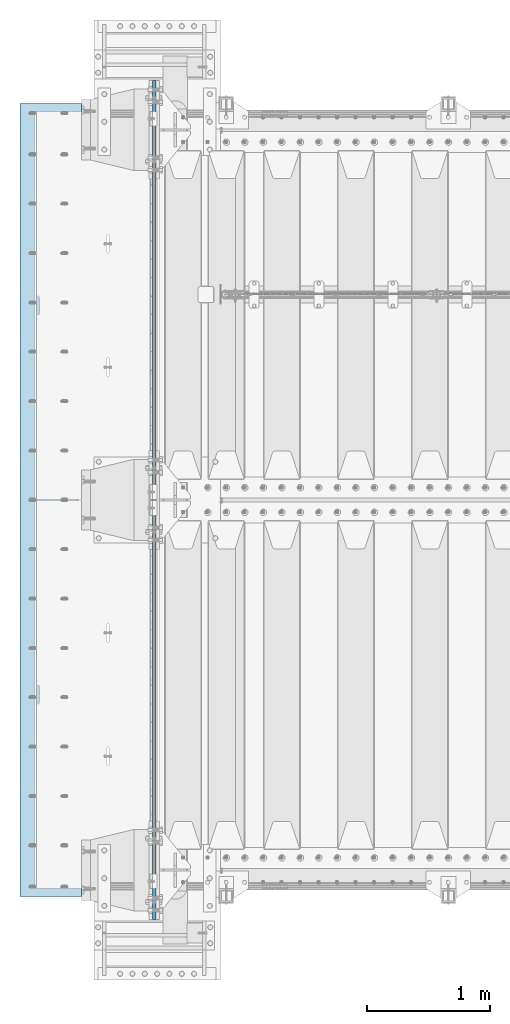
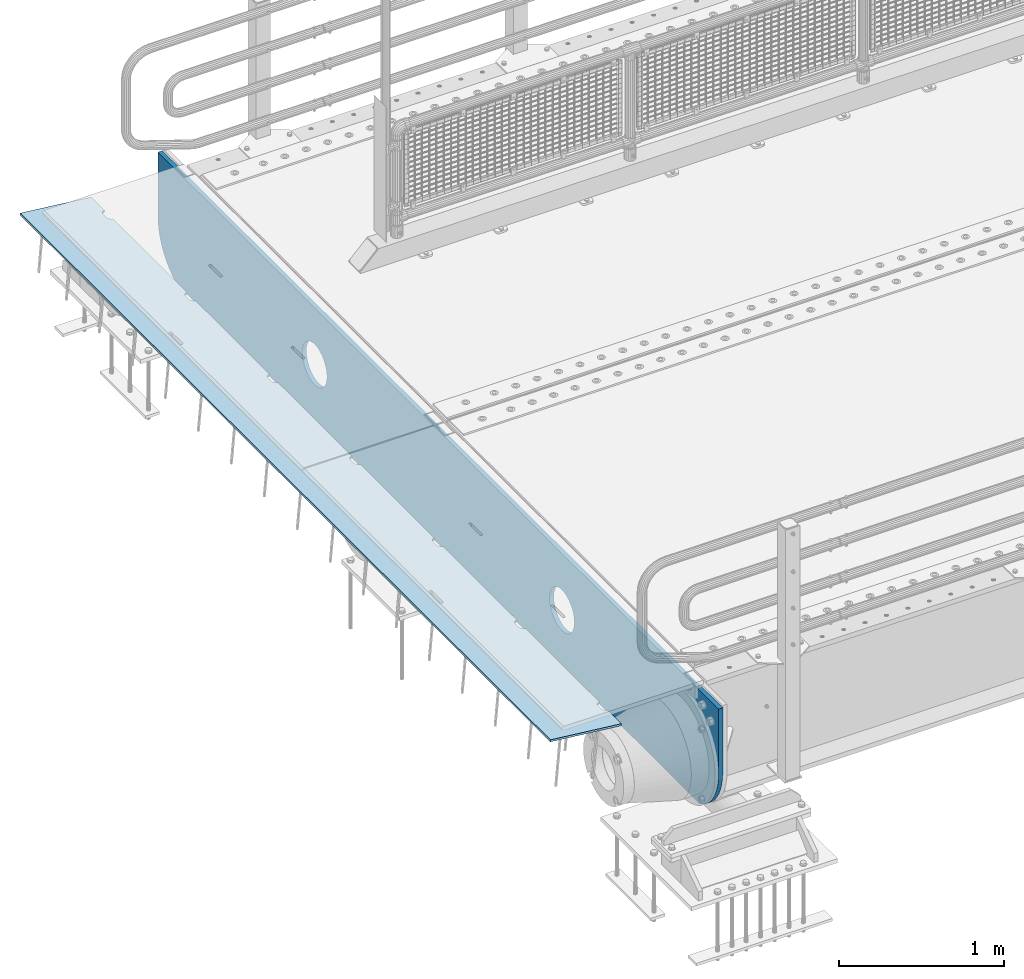
# One storey, part 191 of 242: 2 plates.
"""IFC2X3 building model written with IfcOpenShell, lengths in millimetres."""

from ifc_helpers import new_model, si_unit, frame, origin_with_axes, place, context, subcontext, project, spatial, faceted_brep, material, type_object, element, save


model = new_model("IFC2X3")

# Units and contexts
model_context = context("Model", 3, precision=1e-05, world=origin_with_axes())
body_context = subcontext(model_context, "Body", "Model", "MODEL_VIEW")
ifc_project = project(units=[si_unit("LENGTHUNIT", "METRE", prefix="MILLI"), si_unit("AREAUNIT", "SQUARE_METRE"), si_unit("VOLUMEUNIT", "CUBIC_METRE"), si_unit("MASSUNIT", "GRAM", prefix="KILO"), si_unit("TIMEUNIT", "SECOND"), si_unit("PLANEANGLEUNIT", "RADIAN"), si_unit("SOLIDANGLEUNIT", "STERADIAN"), si_unit("THERMODYNAMICTEMPERATUREUNIT", "DEGREE_CELSIUS"), si_unit("LUMINOUSINTENSITYUNIT", "LUMEN")], contexts=[model_context])

# Site, building, storey
site_placement = place(None, origin_with_axes())
site = spatial("IfcSite", under=ifc_project, at=site_placement, CompositionType="ELEMENT")
building_placement = place(site_placement, origin_with_axes())
building = spatial("IfcBuilding", under=site, at=building_placement, Name="Standard", CompositionType="ELEMENT")
storey_placement = place(building_placement, origin_with_axes())
storey = spatial("IfcBuildingStorey", under=building, at=storey_placement, Name="Undefined", CompositionType="ELEMENT", Elevation=0.0)

# Plates
ifc_material = material(Name="STEEL/S355N")
plate_type_1 = type_object("IfcPlateType", PredefinedType="NOTDEFINED")
plate_1_placement = place(storey_placement, frame((-42485.0, -24400.0, -35.9999830912049), z_axis=(0.0, 1.0, 0.0), x_axis=(0.0, 0.0, -1.0)))
element("IfcPlate", 1, at=plate_1_placement, inside=storey, type_object=plate_type_1, material=ifc_material, context=body_context, shape_type="Brep", body=[
    faceted_brep([(449.263580031862, -15.0, 2047.11778936592), (449.263580031862, 15.0, 2047.11778936592), (477.402546532991, 15.0, 2038.58192701329), (477.402546532991, -15.0, 2038.58192701329), (503.335566547999, 15.0, 2024.72043882638), (503.335566547999, -15.0, 2024.72043882638), (526.066048661114, 15.0, 2006.0660140226), (526.066048661114, -15.0, 2006.0660140226), (544.720473192131, 15.0, 1983.33553168563), (544.720473192131, -15.0, 1983.33553168563), (558.581961067844, 15.0, 1957.40251150429), (558.581961067844, -15.0, 1957.40251150429), (567.117823082802, 15.0, 1929.26354490073), (567.117823082802, -15.0, 1929.26354490073), (570.000030846736, 15.0, 1899.99999658101), (570.000030846736, -15.0, 1899.99999658101), (567.117822731639, 15.0, 1870.73644829589), (567.117822731639, -15.0, 1870.73644829589), (558.581960379014, 15.0, 1842.59748179476), (558.581960379014, -15.0, 1842.59748179476), (544.720472192104, 15.0, 1816.66446177975), (544.720472192104, -15.0, 1816.66446177975), (526.066047388322, 15.0, 1793.93397966664), (526.066047388322, -15.0, 1793.93397966664), (503.335565051353, 15.0, 1775.27955513562), (503.335565051353, -15.0, 1775.27955513562), (477.402544870008, 15.0, 1761.4180672599), (477.402544870008, -15.0, 1761.4180672599), (449.263578266448, 15.0, 1752.88220524495), (449.263578266448, -15.0, 1752.88220524495), (420.000029946736, 15.0, 1749.99999748101), (420.000029946736, -15.0, 1749.99999748101), (390.73648166161, 15.0, 1752.88220559611), (390.73648166161, -15.0, 1752.88220559611), (362.597515160481, 15.0, 1761.41806794873), (362.597515160481, -15.0, 1761.41806794873), (336.664495145473, 15.0, 1775.27955613565), (336.664495145473, -15.0, 1775.27955613565), (313.934013032358, 15.0, 1793.93398093943), (313.934013032358, -15.0, 1793.93398093943), (295.279588501341, 15.0, 1816.6644632764), (295.279588501341, -15.0, 1816.6644632764), (281.418100625628, 15.0, 1842.59748345774), (281.418100625628, -15.0, 1842.59748345774), (272.88223861067, 15.0, 1870.7364500613), (272.88223861067, -15.0, 1870.7364500613), (270.000030846736, 15.0, 1899.99999838101), (270.000030846736, -15.0, 1899.99999838101), (272.882238961832, 15.0, 1929.26354666614), (272.882238961832, -15.0, 1929.26354666614), (281.418101314458, 15.0, 1957.40251316727), (281.418101314458, -15.0, 1957.40251316727), (295.279589501367, 15.0, 1983.33553318228), (295.279589501367, -15.0, 1983.33553318228), (313.93401430515, 15.0, 2006.06601529539), (313.93401430515, -15.0, 2006.06601529539), (336.664496642118, 15.0, 2024.72043982641), (336.664496642118, -15.0, 2024.72043982641), (362.597516823464, 15.0, 2038.58192770212), (362.597516823464, -15.0, 2038.58192770212), (390.736483427023, 15.0, 2047.11778971708), (390.736483427023, -15.0, 2047.11778971708), (420.000031746736, 15.0, 2049.99999748101), (420.000031746736, -15.0, 2049.99999748101), (-9.46818609293132e-07, 15.0, 6800.0), (-9.46818609293132e-07, -15.0, 6800.0), (479.000057698974, -15.0, 6799.9999971271), (479.000057668868, 15.0, 6800.0), (0.0, -15.0, 0.0), (0.0, 15.0, 0.0), (479.000000000116, 15.0, 0.0), (479.000000000116, -15.0, 0.0), (527.214672104542, 15.0, 2.9164503635111), (527.214672104542, -15.0, 2.9164503635111), (574.72626571721, 15.0, 11.6232730319753), (574.72626571721, -15.0, 11.6232730319753), (620.841954818999, 15.0, 25.9935029278749), (620.841954818999, -15.0, 25.9935029278749), (664.889268819315, 15.0, 45.8175897403853), (664.889268819315, -15.0, 45.8175897403853), (706.225898694119, 15.0, 70.8064536438214), (706.225898694119, -15.0, 70.8064536438214), (744.249063297851, 15.0, 100.595700732451), (744.249063297851, -15.0, 100.595700732451), (778.404299269879, 15.0, 134.750936704171), (778.404299269879, -15.0, 134.750936704171), (808.193546358832, 15.0, 172.77410130763), (808.193546358832, -15.0, 172.77410130763), (833.182410262612, 15.0, 214.110731182191), (833.182410262612, -15.0, 214.110731182191), (838.999997962172, -15.0, 227.036880797281), (838.999997962172, 15.0, 227.036880797281), (838.999941002682, 15.0, 6572.96326471486), (838.999941002682, -15.0, 6572.96326478152), (833.182425778571, 14.9999999999927, 6585.88925446616), (833.182425808571, -15.0000000000073, 6585.88925446616), (808.193562547503, 14.9999999999927, 6627.22588611703), (808.193562577503, -15.0000000000073, 6627.22588611703), (778.40431580068, 14.9999999999927, 6665.24905247753), (778.40431583068, -15.0000000000073, 6665.24905247753), (744.249079856288, 14.9999999999927, 6699.40429013451), (744.249079886288, -15.0000000000073, 6699.40429013451), (706.225914989459, 14.9999999999927, 6729.19353878786), (706.225915019459, -15.0000000000073, 6729.19353878786), (664.889284591557, 14.9999999999927, 6754.18240409161), (664.889284621557, -15.0000000000073, 6754.18240409161), (620.841969845021, 14.9999999999927, 6774.00649210192), (620.841969875021, -15.0000000000073, 6774.00649210192), (574.726279815927, 14.9999999999927, 6788.37672296161), (574.726279845927, -15.0000000000073, 6788.37672296161), (527.214685141022, 14.9999999999927, 6797.08354633565), (527.214685171022, -15.0000000000073, 6797.08354633565), (477.402561983564, -15.0, 5038.58192701329), (503.335581998572, -15.0, 5024.72043882638), (526.066064111687, -15.0, 5006.0660140226), (544.720488642704, -15.0, 4983.33553168563), (558.581976518417, -15.0, 4957.40251150429), (567.117838533375, -15.0, 4929.26354490073), (570.000046297309, -15.0, 4899.99999658101), (567.117838182212, -15.0, 4870.73644829589), (558.581975829587, -15.0, 4842.59748179476), (544.720487642677, -15.0, 4816.66446177975), (526.066062838895, -15.0, 4793.93397966664), (503.335580501926, -15.0, 4775.27955513562), (477.402560320581, -15.0, 4761.4180672599), (449.263593717021, -15.0, 4752.88220524495), (420.000045397309, -15.0, 4749.99999748101), (390.736497112183, -15.0, 4752.88220559611), (362.597530611054, -15.0, 4761.41806794873), (336.664510596046, -15.0, 4775.27955613565), (313.93402848293, -15.0, 4793.93398093943), (295.279603951914, -15.0, 4816.6644632764), (281.418116076201, -15.0, 4842.59748345774), (272.882254061243, -15.0, 4870.7364500613), (270.000046297309, -15.0, 4899.99999838101), (272.882254412405, -15.0, 4929.26354666614), (281.418116765031, -15.0, 4957.40251316727), (295.27960495194, -15.0, 4983.33553318228), (313.934029755723, -15.0, 5006.06601529539), (336.664512092691, -15.0, 5024.72043982641), (362.597532274037, -15.0, 5038.58192770212), (390.736498877596, -15.0, 5047.11778971708), (420.000047197309, -15.0, 5049.99999748101), (449.263595482435, -15.0, 5047.11778936592), (362.597532274037, 15.0, 5038.58192770212), (390.736498877596, 15.0, 5047.11778971708), (336.664512092691, 15.0, 5024.72043982641), (313.934029755723, 15.0, 5006.06601529539), (295.27960495194, 15.0, 4983.33553318228), (281.418116765031, 15.0, 4957.40251316727), (272.882254412405, 15.0, 4929.26354666614), (270.000046297309, 15.0, 4899.99999838101), (272.882254061243, 15.0, 4870.7364500613), (281.418116076201, 15.0, 4842.59748345774), (295.279603951914, 15.0, 4816.6644632764), (313.93402848293, 15.0, 4793.93398093943), (336.664510596046, 15.0, 4775.27955613565), (362.597530611054, 15.0, 4761.41806794873), (390.736497112183, 15.0, 4752.88220559611), (420.000045397309, 15.0, 4749.99999748101), (449.263593717021, 15.0, 4752.88220524495), (477.402560320581, 15.0, 4761.4180672599), (503.335580501926, 15.0, 4775.27955513562), (526.066062838895, 15.0, 4793.93397966664), (544.720487642677, 15.0, 4816.66446177975), (558.581975829587, 15.0, 4842.59748179476), (567.117838182212, 15.0, 4870.73644829589), (570.000046297309, 15.0, 4899.99999658101), (567.117838533375, 15.0, 4929.26354490073), (558.581976518417, 15.0, 4957.40251150429), (544.720488642704, 15.0, 4983.33553168563), (526.066064111687, 15.0, 5006.0660140226), (503.335581998572, 15.0, 5024.72043882638), (477.402561983564, 15.0, 5038.58192701329), (449.263595482435, 15.0, 5047.11778936592), (420.000047197309, 15.0, 5049.99999748101)], [[[0, 1, 2, 3]], [[3, 2, 4, 5]], [[5, 4, 6, 7]], [[7, 6, 8, 9]], [[9, 8, 10, 11]], [[11, 10, 12, 13]], [[13, 12, 14, 15]], [[15, 14, 16, 17]], [[17, 16, 18, 19]], [[19, 18, 20, 21]], [[21, 20, 22, 23]], [[23, 22, 24, 25]], [[25, 24, 26, 27]], [[27, 26, 28, 29]], [[29, 28, 30, 31]], [[31, 30, 32, 33]], [[33, 32, 34, 35]], [[35, 34, 36, 37]], [[37, 36, 38, 39]], [[39, 38, 40, 41]], [[41, 40, 42, 43]], [[43, 42, 44, 45]], [[45, 44, 46, 47]], [[47, 46, 48, 49]], [[49, 48, 50, 51]], [[51, 50, 52, 53]], [[53, 52, 54, 55]], [[55, 54, 56, 57]], [[57, 56, 58, 59]], [[59, 58, 60, 61]], [[61, 60, 62, 63]], [[63, 62, 1, 0]], [[64, 65, 66, 67]], [[68, 65, 64, 69]], [[68, 69, 70, 71]], [[71, 70, 72, 73]], [[73, 72, 74, 75]], [[75, 74, 76, 77]], [[77, 76, 78, 79]], [[79, 78, 80, 81]], [[81, 80, 82, 83]], [[83, 82, 84, 85]], [[85, 84, 86, 87]], [[87, 86, 88, 89]], [[90, 89, 88, 91]], [[90, 91, 92, 93]], [[93, 92, 94, 95]], [[95, 94, 96, 97]], [[97, 96, 98, 99]], [[99, 98, 100, 101]], [[101, 100, 102, 103]], [[103, 102, 104, 105]], [[105, 104, 106, 107]], [[107, 106, 108, 109]], [[109, 108, 110, 111]], [[66, 111, 110, 67]], [[65, 68, 71, 73, 75, 77, 79, 81, 83, 85, 87, 89, 90, 93, 95, 97, 99, 101, 103, 105, 107, 109, 111, 66], [3, 5, 7, 9, 11, 13, 15, 17, 19, 21, 23, 25, 27, 29, 31, 33, 35, 37, 39, 41, 43, 45, 47, 49, 51, 53, 55, 57, 59, 61, 63, 0], [112, 113, 114, 115, 116, 117, 118, 119, 120, 121, 122, 123, 124, 125, 126, 127, 128, 129, 130, 131, 132, 133, 134, 135, 136, 137, 138, 139, 140, 141, 142, 143]], [[140, 144, 145, 141]], [[139, 146, 144, 140]], [[138, 147, 146, 139]], [[137, 148, 147, 138]], [[136, 149, 148, 137]], [[135, 150, 149, 136]], [[134, 151, 150, 135]], [[133, 152, 151, 134]], [[132, 153, 152, 133]], [[131, 154, 153, 132]], [[130, 155, 154, 131]], [[129, 156, 155, 130]], [[128, 157, 156, 129]], [[127, 158, 157, 128]], [[126, 159, 158, 127]], [[125, 160, 159, 126]], [[124, 161, 160, 125]], [[123, 162, 161, 124]], [[122, 163, 162, 123]], [[121, 164, 163, 122]], [[120, 165, 164, 121]], [[119, 166, 165, 120]], [[118, 167, 166, 119]], [[117, 168, 167, 118]], [[116, 169, 168, 117]], [[115, 170, 169, 116]], [[114, 171, 170, 115]], [[113, 172, 171, 114]], [[112, 173, 172, 113]], [[143, 174, 173, 112]], [[142, 175, 174, 143]], [[141, 145, 175, 142]], [[108, 106, 104, 102, 100, 98, 96, 94, 92, 91, 88, 86, 84, 82, 80, 78, 76, 74, 72, 70, 69, 64, 67, 110], [58, 56, 54, 52, 50, 48, 46, 44, 42, 40, 38, 36, 34, 32, 30, 28, 26, 24, 22, 20, 18, 16, 14, 12, 10, 8, 6, 4, 2, 1, 62, 60], [144, 146, 147, 148, 149, 150, 151, 152, 153, 154, 155, 156, 157, 158, 159, 160, 161, 162, 163, 164, 165, 166, 167, 168, 169, 170, 171, 172, 173, 174, 175, 145]]]),
])
plate_type_2 = type_object("IfcPlateType", PredefinedType="NOTDEFINED")
plate_2_placement = place(storey_placement, frame((-43074.1812549702, -24215.0, -62.544823504668), z_axis=(-0.994023532708189, -4.00000135296876e-09, 0.109166003967953), x_axis=(0.0, 1.0, 0.0)))
element("IfcPlate", 2, at=plate_2_placement, inside=storey, type_object=plate_type_2, material=ifc_material, context=body_context, shape_type="Brep", body=[
    faceted_brep([(6164.99999999666, -7.49999999999909, 7.33479246264324e-05), (6165.00000000327, 7.50000000000091, -2.18278728425503e-11), (6165.45576743374, 7.5, 5.20976320983755), (6165.4557674272, -7.50000000000091, 5.20976320983755), (6166.80922142074, 7.5, 10.2609221742096), (6166.80922141419, -7.49999999999909, 10.2609221742168), (6169.01923794974, 7.49999999999909, 15.0003178656552), (6169.01923794319, -7.5, 15.0003178656552), (6172.01866678684, 7.5, 19.2839461443291), (6172.01866678029, -7.5, 19.2839461443291), (6175.71637180461, 7.50000000000091, 22.9816511325989), (6175.71637179805, -7.49999999999818, 22.9816511325989), (6180.0000001072, 7.5, 25.9810799355328), (6180.00000010065, -7.5, 25.98107993554), (6184.73939581627, 7.5, 28.1910964267299), (6184.73939580972, -7.49999999999909, 28.1910964267299), (6189.79055479144, 7.50000000000091, 29.5445503734372), (6189.79055478489, -7.49999999999818, 29.5445503734372), (6195.00000012327, 7.50000000000091, 30.0003177623585), (6195.00000011672, -7.49999999999818, 30.0003177623657), (6235.00000012327, 7.50000000000182, 30.0003176033133), (6235.00000011672, -7.49999999999818, 30.0003176033133), (6240.20944545146, 7.5, 29.54455017297), (6240.20944544491, -7.49999999999909, 29.54455017297), (6245.26060441581, 7.50000000000091, 28.1910961860995), (6245.26060440926, -7.49999999999818, 28.1910961860922), (6250.0000001072, 7.49999999999909, 25.9810796571983), (6250.00000010065, -7.49999999999909, 25.9810796572056), (6254.2836283858, 7.5, 22.9816508202057), (6254.28362837925, -7.5, 22.981650820213), (6257.98133337398, 7.5, 19.2839458025337), (6257.98133336743, -7.49999999999818, 19.2839458025264), (6260.98076217681, 7.50000000000091, 15.0003175000093), (6260.98076217026, -7.49999999999909, 15.0003175000093), (6263.1907786679, 7.50000000000091, 10.2609217909921), (6263.19077866134, -7.49999999999818, 10.2609217909849), (6264.54423261448, 7.5, 5.20976281585172), (6264.54423260793, -7.49999999999909, 5.20976281585172), (6264.99999999672, -7.5, 0.000317484031256754), (6265.00000000327, 7.5, -2.18278728425503e-11), (5264.99999999672, -7.49999999999909, 0.000322454179695342), (5264.54423260793, -7.50000000000273, 5.20976778599288), (5264.54423261448, 7.50000000000364, 5.20976778599288), (5265.00000000327, 7.50000000000182, -2.18278728425503e-11), (5263.19077866134, -7.50000000000182, 10.2609267611406), (5263.1907786679, 7.50000000000273, 10.2609267611333), (5260.98076217026, -7.50000000000182, 15.0003224701577), (5260.98076217681, 7.50000000000273, 15.0003224701504), (5257.98133336743, -7.50000000000182, 19.2839507726749), (5257.98133337398, 7.50000000000364, 19.2839507726676), (5254.28362837925, -7.5, 22.9816557903541), (5254.2836283858, 7.50000000000455, 22.9816557903541), (5250.00000010065, -7.50000000000273, 25.9810846273467), (5250.0000001072, 7.50000000000364, 25.9810846273467), (5245.26060440926, -7.50000000000091, 28.1911011562406), (5245.26060441581, 7.50000000000455, 28.1911011562333), (5240.20944544491, -7.50000000000273, 29.5445551431112), (5240.20944545146, 7.50000000000364, 29.5445551431039), (5235.00000011672, -7.50000000000091, 30.0003225734617), (5235.00000012327, 7.50000000000364, 30.0003225734545), (5195.00000011672, -7.5, 30.0003227324996), (5195.00000012327, 7.50000000000455, 30.0003227324996), (5189.79055478489, -7.50000000000182, 29.5445553435857), (5189.79055479144, 7.50000000000364, 29.5445553435857), (5184.73939580972, -7.50000000000273, 28.1911013968711), (5184.73939581627, 7.50000000000273, 28.1911013968711), (5180.00000010065, -7.50000000000182, 25.9810849056812), (5180.0000001072, 7.50000000000546, 25.9810849056812), (5175.71637179805, -7.50000000000182, 22.9816561027474), (5175.71637180461, 7.50000000000364, 22.9816561027401), (5172.01866678029, -7.50000000000182, 19.283951114463), (5172.01866678684, 7.50000000000364, 19.283951114463), (5169.01923794319, -7.50000000000091, 15.0003228358037), (5169.01923794974, 7.50000000000455, 15.0003228357964), (5166.80922141419, -7.50000000000091, 10.260927144358), (5166.80922142074, 7.50000000000455, 10.260927144358), (5165.4557674272, -7.50000000000182, 5.20976817997871), (5165.45576743374, 7.50000000000455, 5.20976817997143), (5164.9999999967, -7.49999999999909, 0.000191312581591774), (5165.00000000327, 7.50000000000091, -2.18278728425503e-11), (4264.99999999672, -7.49999999999909, 0.000327424313582014), (4265.00000000327, 7.50000000000091, -2.18278728425503e-11), (4264.54423260793, -7.49999999999909, 5.20977275613404), (4264.54423261448, 7.50000000000273, 5.20977275613404), (4263.19077866134, -7.50000000000091, 10.2609317312817), (4263.1907786679, 7.50000000000182, 10.2609317312817), (4260.98076217026, -7.5, 15.0003274402989), (4260.98076217681, 7.50000000000182, 15.0003274402989), (4257.98133336743, -7.5, 19.2839557428233), (4257.98133337398, 7.50000000000273, 19.2839557428233), (4254.28362837925, -7.50000000000091, 22.9816607604953), (4254.2836283858, 7.50000000000364, 22.981660760488), (4250.00000010065, -7.5, 25.9810895974879), (4250.0000001072, 7.50000000000182, 25.9810895974806), (4245.26060440926, -7.5, 28.1911061263672), (4245.26060441581, 7.50000000000273, 28.1911061263745), (4240.20944544491, -7.5, 29.5445601132524), (4240.20944545146, 7.50000000000364, 29.5445601132524), (4235.00000011672, -7.50000000000091, 30.0003275435956), (4235.00000012327, 7.50000000000182, 30.0003275435956), (4195.00000011672, -7.50000000000091, 30.0003277026481), (4195.00000012327, 7.50000000000273, 30.0003277026408), (4189.79055478489, -7.50000000000091, 29.5445603137268), (4189.79055479144, 7.50000000000273, 29.5445603137268), (4184.73939580972, -7.50000000000091, 28.1911063670123), (4184.73939581627, 7.50000000000182, 28.1911063670123), (4180.00000010065, -7.50000000000091, 25.9810898758151), (4180.0000001072, 7.50000000000364, 25.9810898758151), (4175.71637179805, -7.50000000000091, 22.9816610728813), (4175.71637180461, 7.50000000000182, 22.9816610728813), (4172.01866678029, -7.5, 19.2839560846187), (4172.01866678684, 7.50000000000364, 19.2839560846187), (4169.01923794319, -7.50000000000091, 15.0003278059448), (4169.01923794974, 7.50000000000273, 15.0003278059448), (4166.80922141419, -7.50000000000091, 10.2609321145064), (4166.80922142074, 7.50000000000364, 10.2609321144992), (4165.4557674272, -7.50000000000091, 5.20977315011987), (4165.45576743374, 7.50000000000273, 5.20977315011987), (4164.99999999671, -7.5, 0.000237874701269902), (4165.00000000327, 7.5, -1.45519152283669e-11), (3264.99999999672, -7.49999999999909, 0.000332394462020602), (3265.00000000327, 7.50000000000091, -1.45519152283669e-11), (3264.54423260793, -7.49999999999909, 5.20977772627521), (3264.54423261448, 7.50000000000364, 5.20977772627521), (3263.19077866134, -7.49999999999818, 10.2609367014229), (3263.1907786679, 7.50000000000455, 10.2609367014156), (3260.98076217026, -7.49999999999909, 15.0003324104473), (3260.98076217681, 7.50000000000364, 15.00033241044), (3257.98133336743, -7.49999999999818, 19.2839607129645), (3257.98133337398, 7.50000000000455, 19.2839607129572), (3254.28362837925, -7.5, 22.9816657306365), (3254.2836283858, 7.50000000000364, 22.9816657306365), (3250.00000010065, -7.49999999999818, 25.981094567629), (3250.0000001072, 7.50000000000364, 25.981094567629), (3245.26060440926, -7.49999999999909, 28.1911110965157), (3245.26060441581, 7.50000000000364, 28.1911110965084), (3240.20944544491, -7.49999999999909, 29.5445650834008), (3240.20944545146, 7.50000000000455, 29.5445650833935), (3235.00000011672, -7.5, 30.0003325137513), (3235.00000012327, 7.50000000000364, 30.0003325137441), (3195.00000011672, -7.49999999999909, 30.000332672782), (3195.00000012327, 7.50000000000455, 30.000332672782), (3189.79055478489, -7.49999999999909, 29.5445652838607), (3189.79055479144, 7.50000000000455, 29.5445652838607), (3184.73939580972, -7.5, 28.1911113371534), (3184.73939581627, 7.50000000000455, 28.1911113371607), (3180.00000010065, -7.49999999999909, 25.9810948459563), (3180.0000001072, 7.50000000000364, 25.9810948459563), (3175.71637179805, -7.49999999999818, 22.9816660430297), (3175.71637180461, 7.50000000000364, 22.9816660430297), (3172.01866678029, -7.49999999999909, 19.2839610547526), (3172.01866678684, 7.50000000000364, 19.2839610547526), (3169.01923794319, -7.49999999999909, 15.000332776086), (3169.01923794974, 7.50000000000364, 15.0003327760787), (3166.80922141419, -7.49999999999909, 10.2609370846403), (3166.80922142074, 7.50000000000364, 10.2609370846403), (3165.4557674272, -7.49999999999909, 5.20977812025376), (3165.45576743374, 7.50000000000273, 5.20977812026103), (3164.99999999672, -7.5, 0.00026446467381902), (3165.00000000327, 7.50000000000091, -1.45519152283669e-11), (2264.99999999672, -7.5, 0.000337364603183232), (2265.00000000327, 7.50000000000091, -7.27595761418343e-12), (2264.54423260793, -7.5, 5.20978269642364), (2264.54423261448, 7.50000000000273, 5.20978269642364), (2263.19077866134, -7.49999999999909, 10.2609416715713), (2263.1907786679, 7.50000000000364, 10.2609416715713), (2260.98076217026, -7.49999999999909, 15.0003373805885), (2260.98076217681, 7.50000000000364, 15.0003373805885), (2257.98133336743, -7.5, 19.2839656831056), (2257.98133337398, 7.50000000000364, 19.2839656831056), (2254.28362837925, -7.5, 22.9816707007849), (2254.2836283858, 7.50000000000182, 22.9816707007776), (2250.00000010065, -7.49999999999909, 25.9810995377848), (2250.0000001072, 7.50000000000364, 25.981099537792), (2245.26060440926, -7.5, 28.1911160666714), (2245.26060441581, 7.50000000000273, 28.1911160666714), (2240.20944544491, -7.49999999999909, 29.5445700535493), (2240.20944545146, 7.50000000000273, 29.5445700535493), (2235.00000011672, -7.49999999999818, 30.0003374838852), (2235.00000012327, 7.50000000000364, 30.0003374838852), (2195.00000011672, -7.49999999999909, 30.0003376429377), (2195.00000012327, 7.50000000000273, 30.0003376429304), (2189.79055478489, -7.49999999999909, 29.5445702540092), (2189.79055479144, 7.50000000000182, 29.5445702540092), (2184.73939580972, -7.49999999999818, 28.1911163073164), (2184.73939581627, 7.50000000000364, 28.1911163073091), (2180.00000010065, -7.5, 25.981099816112), (2180.0000001072, 7.50000000000364, 25.9810998161047), (2175.71637179805, -7.49999999999818, 22.9816710131636), (2175.71637180461, 7.50000000000273, 22.9816710131636), (2172.01866678029, -7.5, 19.283966024901), (2172.01866678684, 7.50000000000273, 19.283966024901), (2169.01923794319, -7.5, 15.0003377462344), (2169.01923794974, 7.50000000000364, 15.0003377462344), (2166.80922141419, -7.49999999999909, 10.2609420547888), (2166.80922142074, 7.50000000000182, 10.2609420547888), (2165.4557674272, -7.5, 5.20978309040947), (2165.45576743374, 7.50000000000273, 5.20978309040947), (2164.99999999672, -7.5, 0.000282683002296835), (2165.00000000327, 7.50000000000091, 0.0), (1264.99999999672, -7.5, 0.00034233475162182), (1265.00000000327, 7.5, 0.0), (1264.54423260793, -7.5, 5.20978766657208), (1264.54423261448, 7.50000000000182, 5.20978766656481), (1263.19077866134, -7.49999999999909, 10.2609466417125), (1263.1907786679, 7.50000000000182, 10.2609466417052), (1260.98076217026, -7.5, 15.0003423507296), (1260.98076217681, 7.50000000000091, 15.0003423507296), (1257.98133336743, -7.49999999999909, 19.2839706532468), (1257.98133337398, 7.50000000000182, 19.2839706532468), (1254.28362837925, -7.49999999999909, 22.9816756709261), (1254.2836283858, 7.50000000000182, 22.9816756709261), (1250.00000010065, -7.49999999999909, 25.9811045079186), (1250.0000001072, 7.50000000000182, 25.9811045079186), (1245.26060440926, -7.49999999999909, 28.1911210368125), (1245.26060441581, 7.50000000000091, 28.1911210368125), (1240.20944544491, -7.5, 29.5445750236831), (1240.20944545146, 7.50000000000182, 29.5445750236759), (1235.00000011672, -7.49999999999909, 30.0003424540337), (1235.00000012327, 7.50000000000091, 30.0003424540264), (1195.00000011672, -7.49999999999909, 30.0003426130716), (1195.00000012327, 7.5, 30.0003426130716), (1189.79055478489, -7.49999999999909, 29.5445752241576), (1189.79055479144, 7.50000000000182, 29.5445752241576), (1184.73939580972, -7.5, 28.191121277443), (1184.73939581627, 7.50000000000182, 28.1911212774503), (1180.00000010065, -7.49999999999818, 25.9811047862531), (1180.0000001072, 7.50000000000091, 25.9811047862531), (1175.71637179805, -7.49999999999909, 22.9816759833193), (1175.71637180461, 7.50000000000273, 22.9816759833193), (1172.01866678029, -7.5, 19.2839709950422), (1172.01866678684, 7.50000000000091, 19.2839709950422), (1169.01923794319, -7.49999999999909, 15.0003427163756), (1169.01923794974, 7.50000000000091, 15.0003427163683), (1166.80922141419, -7.49999999999909, 10.2609470249299), (1166.80922142074, 7.50000000000182, 10.2609470249299), (1165.4557674272, -7.49999999999909, 5.20978806055064), (1165.45576743374, 7.50000000000182, 5.20978806055791), (1164.99999999672, -7.49999999999909, 0.000296603444439825), (1165.00000000327, 7.50000000000091, 0.0), (264.999999996722, -7.5, 0.000347304885508493), (265.000000003274, 7.50000000000091, 0.0), (264.544232607932, -7.49999999999909, 5.20979263670597), (264.54423261448, 7.50000000000091, 5.20979263670597), (263.190778661345, -7.5, 10.2609516118537), (263.190778667897, 7.5, 10.2609516118537), (260.98076217026, -7.49999999999909, 15.0003473208708), (260.980762176809, 7.50000000000091, 15.0003473208708), (257.981333367428, -7.5, 19.2839756233952), (257.981333373977, 7.5, 19.2839756233952), (254.283628379246, -7.5, 22.9816806410672), (254.283628385798, 7.50000000000091, 22.9816806410672), (250.000000100648, -7.5, 25.9811094780598), (250.000000107197, 7.50000000000091, 25.9811094780671), (245.260604409257, -7.5, 28.1911260069537), (245.260604415806, 7.5, 28.1911260069537), (240.209445444911, -7.49999999999909, 29.5445799938243), (240.209445451459, 7.5, 29.5445799938243), (235.000000116725, -7.5, 30.0003474241676), (235.000000123273, 7.5, 30.0003474241676), (195.000000116725, -7.5, 30.00034758322), (195.000000123273, 7.5, 30.00034758322), (189.790554784893, -7.5, 29.544580194306), (189.790554791442, 7.5, 29.5445801942988), (184.73939580972, -7.49999999999909, 28.1911262475915), (184.739395816268, 7.50000000000091, 28.1911262475842), (180.000000100648, -7.49999999999909, 25.9811097563943), (180.000000107197, 7.50000000000091, 25.9811097563943), (175.716371798055, -7.49999999999909, 22.9816809534605), (175.716371804607, 7.5, 22.9816809534605), (172.018666780288, -7.49999999999909, 19.2839759651906), (172.018666786837, 7.50000000000091, 19.2839759651906), (169.019237943194, -7.5, 15.0003476865168), (169.019237949742, 7.50000000000091, 15.0003476865168), (166.809221414187, -7.49999999999909, 10.2609519950711), (166.809221420739, 7.5, 10.2609519950784), (165.455767427196, -7.49999999999909, 5.20979303069907), (165.455767433745, 7.50000000000091, 5.2097930306918), (164.999999996722, -7.49999999999909, 0.0), (165.000000003274, 7.50000000000182, 7.27595761418343e-12), (-7.105427357601e-15, -7.5, 3.63797880709171e-12), (-7.105427357601e-15, 7.5, 3.63797880709171e-12), (1.72946238308214e-06, -7.49999999999909, 500.002441406257), (1.72945874510333e-06, 7.50000000000091, 500.002441406257), (6430.00000001195, -7.49999999999909, 500.002380371094), (6430.00000001195, 7.50000000000091, 500.002380371094), (6430.0, -7.5, -2.91038304567337e-11), (6430.0, 7.50000000000091, -2.18278728425503e-11)], [[[0, 1, 2, 3]], [[3, 2, 4, 5]], [[5, 4, 6, 7]], [[7, 6, 8, 9]], [[9, 8, 10, 11]], [[11, 10, 12, 13]], [[13, 12, 14, 15]], [[15, 14, 16, 17]], [[17, 16, 18, 19]], [[19, 18, 20, 21]], [[21, 20, 22, 23]], [[23, 22, 24, 25]], [[25, 24, 26, 27]], [[27, 26, 28, 29]], [[29, 28, 30, 31]], [[31, 30, 32, 33]], [[33, 32, 34, 35]], [[35, 34, 36, 37]], [[38, 37, 36, 39]], [[40, 41, 42, 43]], [[44, 45, 42, 41]], [[46, 47, 45, 44]], [[48, 49, 47, 46]], [[50, 51, 49, 48]], [[52, 53, 51, 50]], [[54, 55, 53, 52]], [[56, 57, 55, 54]], [[58, 59, 57, 56]], [[60, 61, 59, 58]], [[62, 63, 61, 60]], [[64, 65, 63, 62]], [[66, 67, 65, 64]], [[68, 69, 67, 66]], [[70, 71, 69, 68]], [[72, 73, 71, 70]], [[74, 75, 73, 72]], [[76, 77, 75, 74]], [[78, 79, 77, 76]], [[80, 81, 79, 78]], [[80, 82, 83, 81]], [[84, 85, 83, 82]], [[86, 87, 85, 84]], [[88, 89, 87, 86]], [[90, 91, 89, 88]], [[92, 93, 91, 90]], [[94, 95, 93, 92]], [[96, 97, 95, 94]], [[98, 99, 97, 96]], [[100, 101, 99, 98]], [[102, 103, 101, 100]], [[104, 105, 103, 102]], [[106, 107, 105, 104]], [[108, 109, 107, 106]], [[110, 111, 109, 108]], [[112, 113, 111, 110]], [[114, 115, 113, 112]], [[116, 117, 115, 114]], [[118, 119, 117, 116]], [[120, 121, 119, 118]], [[120, 122, 123, 121]], [[124, 125, 123, 122]], [[126, 127, 125, 124]], [[128, 129, 127, 126]], [[130, 131, 129, 128]], [[132, 133, 131, 130]], [[134, 135, 133, 132]], [[136, 137, 135, 134]], [[138, 139, 137, 136]], [[140, 141, 139, 138]], [[142, 143, 141, 140]], [[144, 145, 143, 142]], [[146, 147, 145, 144]], [[148, 149, 147, 146]], [[150, 151, 149, 148]], [[152, 153, 151, 150]], [[154, 155, 153, 152]], [[156, 157, 155, 154]], [[158, 159, 157, 156]], [[160, 161, 159, 158]], [[160, 162, 163, 161]], [[164, 165, 163, 162]], [[166, 167, 165, 164]], [[168, 169, 167, 166]], [[170, 171, 169, 168]], [[172, 173, 171, 170]], [[174, 175, 173, 172]], [[176, 177, 175, 174]], [[178, 179, 177, 176]], [[180, 181, 179, 178]], [[182, 183, 181, 180]], [[184, 185, 183, 182]], [[186, 187, 185, 184]], [[188, 189, 187, 186]], [[190, 191, 189, 188]], [[192, 193, 191, 190]], [[194, 195, 193, 192]], [[196, 197, 195, 194]], [[198, 199, 197, 196]], [[200, 201, 199, 198]], [[200, 202, 203, 201]], [[204, 205, 203, 202]], [[206, 207, 205, 204]], [[208, 209, 207, 206]], [[210, 211, 209, 208]], [[212, 213, 211, 210]], [[214, 215, 213, 212]], [[216, 217, 215, 214]], [[218, 219, 217, 216]], [[220, 221, 219, 218]], [[222, 223, 221, 220]], [[224, 225, 223, 222]], [[226, 227, 225, 224]], [[228, 229, 227, 226]], [[230, 231, 229, 228]], [[232, 233, 231, 230]], [[234, 235, 233, 232]], [[236, 237, 235, 234]], [[238, 239, 237, 236]], [[240, 241, 239, 238]], [[240, 242, 243, 241]], [[244, 245, 243, 242]], [[246, 247, 245, 244]], [[248, 249, 247, 246]], [[250, 251, 249, 248]], [[252, 253, 251, 250]], [[254, 255, 253, 252]], [[256, 257, 255, 254]], [[258, 259, 257, 256]], [[260, 261, 259, 258]], [[262, 263, 261, 260]], [[264, 265, 263, 262]], [[266, 267, 265, 264]], [[268, 269, 267, 266]], [[270, 271, 269, 268]], [[272, 273, 271, 270]], [[274, 275, 273, 272]], [[276, 277, 275, 274]], [[278, 279, 277, 276]], [[280, 281, 279, 278]], [[280, 282, 283, 281]], [[282, 284, 285, 283]], [[284, 286, 287, 285]], [[287, 286, 38, 39]], [[34, 32, 30, 28, 26, 24, 22, 20, 18, 16, 14, 12, 10, 8, 6, 4, 2, 1, 43, 42, 45, 47, 49, 51, 53, 55, 57, 59, 61, 63, 65, 67, 69, 71, 73, 75, 77, 79, 81, 83, 85, 87, 89, 91, 93, 95, 97, 99, 101, 103, 105, 107, 109, 111, 113, 115, 117, 119, 121, 123, 125, 127, 129, 131, 133, 135, 137, 139, 141, 143, 145, 147, 149, 151, 153, 155, 157, 159, 161, 163, 165, 167, 169, 171, 173, 175, 177, 179, 181, 183, 185, 187, 189, 191, 193, 195, 197, 199, 201, 203, 205, 207, 209, 211, 213, 215, 217, 219, 221, 223, 225, 227, 229, 231, 233, 235, 237, 239, 241, 243, 245, 247, 249, 251, 253, 255, 257, 259, 261, 263, 265, 267, 269, 271, 273, 275, 277, 279, 281, 283, 285, 287, 39, 36]], [[40, 43, 1, 0]], [[286, 284, 282, 280, 278, 276, 274, 272, 270, 268, 266, 264, 262, 260, 258, 256, 254, 252, 250, 248, 246, 244, 242, 240, 238, 236, 234, 232, 230, 228, 226, 224, 222, 220, 218, 216, 214, 212, 210, 208, 206, 204, 202, 200, 198, 196, 194, 192, 190, 188, 186, 184, 182, 180, 178, 176, 174, 172, 170, 168, 166, 164, 162, 160, 158, 156, 154, 152, 150, 148, 146, 144, 142, 140, 138, 136, 134, 132, 130, 128, 126, 124, 122, 120, 118, 116, 114, 112, 110, 108, 106, 104, 102, 100, 98, 96, 94, 92, 90, 88, 86, 84, 82, 80, 78, 76, 74, 72, 70, 68, 66, 64, 62, 60, 58, 56, 54, 52, 50, 48, 46, 44, 41, 40, 0, 3, 5, 7, 9, 11, 13, 15, 17, 19, 21, 23, 25, 27, 29, 31, 33, 35, 37, 38]]]),
])

save(model, "model.ifc")
